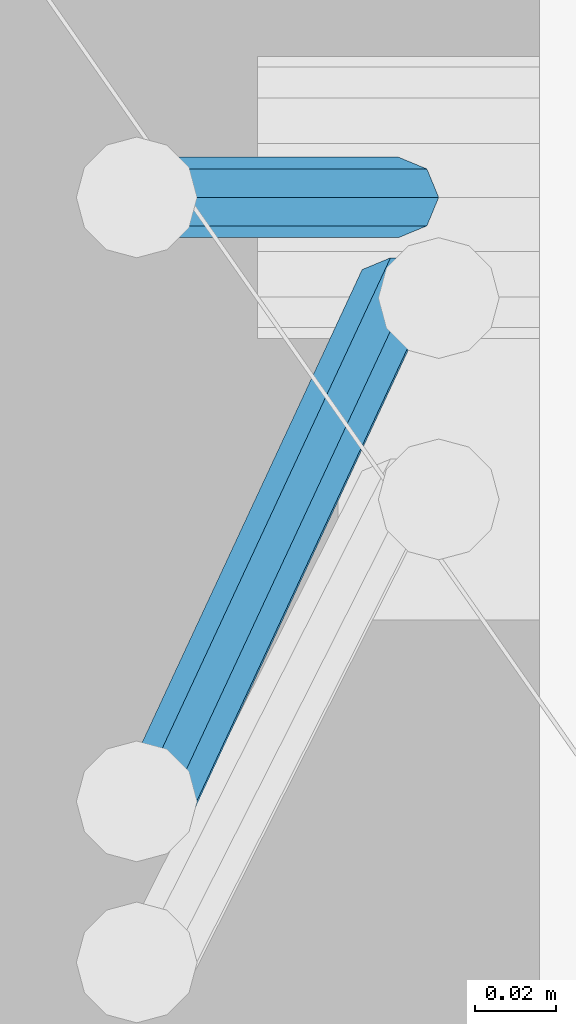
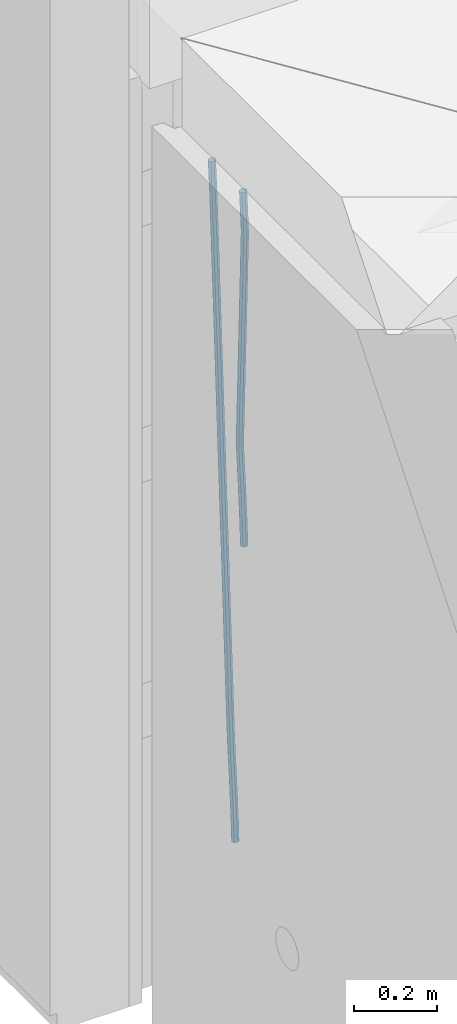
# One storey, part 106 of 309: 2 beams, 1 element without a shape of its own.
"""IFC2X3 building model written with IfcOpenShell, lengths in millimetres."""

from ifc_helpers import new_model, si_unit, frame, origin_with_axes, place, context, subcontext, project, spatial, faceted_brep, material, type_object, element, aggregate, save


model = new_model("IFC2X3")

# Units and contexts
model_context = context("Model", 3, precision=1e-05, world=origin_with_axes())
body_context = subcontext(model_context, "Body", "Model", "MODEL_VIEW")
ifc_project = project(units=[si_unit("LENGTHUNIT", "METRE", prefix="MILLI"), si_unit("AREAUNIT", "SQUARE_METRE"), si_unit("VOLUMEUNIT", "CUBIC_METRE"), si_unit("MASSUNIT", "GRAM", prefix="KILO"), si_unit("TIMEUNIT", "SECOND"), si_unit("PLANEANGLEUNIT", "RADIAN"), si_unit("SOLIDANGLEUNIT", "STERADIAN"), si_unit("THERMODYNAMICTEMPERATUREUNIT", "DEGREE_CELSIUS"), si_unit("LUMINOUSINTENSITYUNIT", "LUMEN")], contexts=[model_context])

# Site, building, storey
site_placement = place(None, origin_with_axes())
site = spatial("IfcSite", under=ifc_project, at=site_placement, CompositionType="ELEMENT")
building_placement = place(site_placement, origin_with_axes())
building = spatial("IfcBuilding", under=site, at=building_placement, CompositionType="ELEMENT")
storey_placement = place(building_placement, origin_with_axes())
storey = spatial("IfcBuildingStorey", under=building, at=storey_placement, Name="7", CompositionType="ELEMENT", Elevation=0.0)

# Assembly, beams
assembly_placement = place(storey_placement, origin_with_axes())
assembly = element("IfcElementAssembly", 1, at=assembly_placement, inside=storey, Name="W1", AssemblyPlace="NOTDEFINED", PredefinedType="REINFORCEMENT_UNIT")
ifc_material = material()
beam_type = type_object("IfcBeamType", Name="D20", PredefinedType="NOTDEFINED")
beam_1_placement = place(assembly_placement, frame((22385.0000022791, 20260.0000000039, 101267.5), z_axis=(-0.999642804636942, -0.000205726999925762, -0.0267249099902983), x_axis=(-0.0267249099948371, 4.30000201934385e-08, 0.999642825806181)))
beam_1 = element("IfcBeam", 2, at=beam_1_placement, type_object=beam_type, material=ifc_material, Name="JM20", ObjectType="D20", context=body_context, shape_type="Brep", body=[
    faceted_brep([(0.0, -10.0, 0.0), (-4.19531716033816e-08, -7.07106781186667, -7.07106781187031), (60.4266690400545, -7.0710677960451, -7.07106780570757), (60.4266690441291, -9.99999998418934, 6.15546014159918e-09), (0.0, 0.0, -10.0), (60.426669036824, 1.58106558956206e-08, -9.99999999384454), (4.196772351861e-08, 7.07106781186303, -7.07106781186667), (60.4266690363438, 7.07106782768096, -7.07106780570757), (0.0, 10.0, 0.0), (60.4266690388904, 10.0000000158179, 6.15182216279209e-09), (4.196772351861e-08, 7.07106781185939, 7.07106781185939), (60.4266690429649, 7.07106782768096, 7.07106781802577), (0.0, 0.0, 10.0), (60.4266690461809, 1.58179318532348e-08, 10.0000000061555), (-4.19531716033816e-08, -7.07106781187031, 7.07106781185939), (60.4266690466611, -7.07106779605238, 7.07106781802213), (61.0378400410118, -7.07106779588503, -7.07106780564936), (60.991799419251, -9.99999998403655, 6.21366780251265e-09), (61.0569027789461, 1.5985278878361e-08, -9.99999999378269), (61.0378209396877, 7.07106782784831, -7.07106780564936), (60.9917724058905, 10.0000000159635, 6.21366780251265e-09), (60.9457317841297, 7.07106782781193, 7.0710678180767), (60.9266690461809, 1.59488990902901e-08, 10.0000000062028), (60.9457508854539, -7.07106779591413, 7.0710678180767), (61.6489592143771, -7.07106614513759, -7.06310863441468), (61.5568818710308, -9.9999984576425, 0.00735959856683621), (61.6870830769039, 1.71821739058942e-06, -9.99179257185824), (61.6489210170112, 7.07106947854481, -7.06310888312146), (61.556827851804, 10.0000015422847, 0.00735924683976918), (61.4647505084577, 7.07106922979438, 7.07782747982128), (61.4266266459163, 1.36643211590126e-06, 10.0065114172685), (61.464788705809, -7.07106639389531, 7.07782772852806), (176.543135720174, -7.07075579406956, -5.56673531796696), (176.451058376813, -9.99968810657447, 1.50373291501455), (176.581259582701, 0.000312069292704109, -8.49541925541052), (176.543097522794, 7.07137982961285, -5.56673556667374), (176.451004357587, 10.00031189336, 1.50373256329476), (176.35892701424, 7.07137958085514, 8.57420079627263), (176.320803151699, 0.000311717507429421, 11.5028847337162), (176.358965211621, -7.07075604281999, 8.57420104497578), (177.098753836006, -7.07075429323595, -5.55949898843028), (176.98362511232, -9.99968666800123, 1.510669025065), (177.146421932586, 0.000313595905026887, -8.48805862247536), (177.098706077581, 7.07138133041735, -5.55949936166144), (176.983557571715, 10.0003133318824, 1.51066849724157), (176.868428848029, 7.07138095712435, 8.58083651073321), (176.820760751449, 0.000313067976094317, 11.5093961447819), (176.868476606425, -7.07075466652896, 8.58083688396073), (177.654312950661, -7.07075204110879, -5.54863964998367), (177.516135294456, -9.99968450931192, 1.52107783331303), (177.711524267797, 0.000315886711177882, -8.47701274570863), (177.654255632195, 7.07138358250813, -5.54864021007961), (177.516054233929, 10.0003154905207, 1.5210770412159), (177.377876577739, 7.0713830223176, 8.59079452451624), (177.320665260588, 0.000315094497636892, 11.5191676202448), (177.377933896176, -7.07075260129932, 8.59079508461218), (298.747348659163, -7.07026115178815, -3.18167234769862), (298.609171002972, -9.99919361999127, 3.88804513559444), (298.804559976241, 0.000806776042736601, -6.11004544342359), (298.747291340609, 7.07187447182878, -3.18167290779093), (298.6090899423, 10.0008063798487, 3.88804434350459), (298.470912286124, 7.07187391164553, 10.9577618268013), (298.413700969017, 0.000805983818281675, 13.8861349225299), (298.470969604663, -7.07026171197504, 10.9577623868936), (299.621796148553, -7.07025760694523, -3.16457979895495), (299.109075512111, -9.99919159347337, 3.89781661105735), (300.339527547287, 0.000812998507171869, -6.08004191737928), (300.841832389109, 7.07188296269669, -3.14073157581515), (300.834467310124, 10.0008154011011, 3.93154309166857), (300.321746673711, 7.071881414573, 10.9939395016918), (299.604015274963, 0.000810809124232037, 13.9094016201125), (299.10171043314, -7.07025915506892, 10.9700912785447), (300.482221804094, -7.22003554013645, -3.11783764522261), (299.6009640134, -10.0848167054246, 3.92453818520153), (301.849881793387, -0.262100753436243, -5.99799274798715), (302.902787308223, 6.71312382273391, -3.02877132562207), (303.024160577959, 9.61964623225504, 4.05049698233779), (302.142902787265, 6.75486506696689, 11.0928728127619), (300.775242797987, -0.203069719733321, 13.9730279155228), (299.722337283136, -7.17829429590347, 11.0038064931578), (1015.90349195308, -131.756442041384, 35.7470320599059), (1015.02223416237, -134.621223206676, 42.78940789033), (1017.27115194236, -124.798507254684, 32.8668769571414), (1018.3240574572, -117.823282678513, 35.8360983795064), (1018.44543072693, -114.916760268996, 42.915366687459), (1017.56417293624, -117.781541434284, 49.9577425178868), (1016.19651294696, -124.739476220984, 52.8378976206477), (1015.14360743211, -131.714700797158, 49.8686761982863), (1017.59248966523, -132.050453017066, 35.8387859380055), (1017.08266705039, -134.979891474468, 42.9013397814706), (1018.34688015285, -124.985763814278, 32.9253153045684), (1018.90392679691, -117.924222987145, 35.8675994646364), (1018.93731922821, -115.002385380943, 42.9420882616032), (1018.42749661337, -117.931823838349, 50.0046421050574), (1017.67310612575, -124.996513041137, 52.9181127385018), (1017.11605948168, -132.058053868273, 49.9758285784337), (1019.30904188578, -132.072836907508, 35.8616318370878), (1019.17671408414, -135.007197908155, 42.9292098262158), (1019.44015792056, -125.00002018789, 32.9398659330036), (1019.4932561936, -117.931907859464, 35.8754429544861), (1019.43723245666, -115.008904263857, 42.9487416957491), (1019.30490465506, -117.943265264505, 50.0163196848807), (1019.17378862025, -125.016081984126, 52.9380855889722), (1019.12069034722, -132.084194312552, 50.0025085674824), (1040.41841779022, -132.348103777858, 36.1425802788253), (1040.28608998859, -135.282464778498, 43.2101582679534), (1040.549533825, -125.275287058234, 33.2208143747339), (1040.60263209805, -118.207174729807, 36.15639139622), (1040.54660836112, -115.284171134201, 43.2296901374903), (1040.4142805595, -118.218532134852, 50.2972681266147), (1040.28316452471, -125.291348854476, 53.2190340307025), (1040.23006625166, -132.359461182896, 50.2834570092164), (1041.05380549764, -132.356389251876, 36.1510367669325), (1040.94617491473, -135.291072304968, 43.2189434557404), (1041.1277784054, -125.282827384228, 33.2285103347931), (1041.1247613119, -118.213983309812, 36.1633405068787), (1041.04652158958, -115.290690017111, 43.2363435716397), (1040.93889100666, -118.225373070203, 50.3042502604476), (1040.8649180989, -125.298934937851, 53.226776692587), (1040.86793519241, -132.367779012271, 50.2919465205014), (1041.68924701435, -132.354514251791, 36.1592989706915), (1041.60631558315, -135.289103781222, 43.2275342832399), (1041.70607222033, -125.28113101716, 33.2360113880059), (1041.64693522363, -118.212446044308, 36.1700937543865), (1041.54647767487, -115.289199122199, 43.2428004127432), (1041.46354624369, -118.223788651623, 50.3110357252881), (1041.4467210377, -125.297171886254, 53.2343233079773), (1041.50585803439, -132.365856859102, 50.3002409415931), (1141.71003490323, -132.056251387494, 37.4566732324238), (1141.62710347204, -134.990840916926, 44.5249085449723), (1141.72686010921, -124.982868152867, 34.5333856497382), (1141.66772311251, -117.914183180015, 37.4674680161224), (1141.56726556375, -114.990936257902, 44.5401746744756), (1141.48433413258, -117.92552578733, 51.6084099870168), (1141.46750892658, -124.998909021961, 54.5316975697097), (1141.52664592327, -132.067593994809, 51.5976152033254)], [[[0, 1, 2, 3]], [[1, 4, 5, 2]], [[4, 6, 7, 5]], [[6, 8, 9, 7]], [[8, 10, 11, 9]], [[10, 12, 13, 11]], [[12, 14, 15, 13]], [[14, 0, 3, 15]], [[14, 12, 10, 8, 6, 4, 1, 0]], [[3, 2, 16, 17]], [[2, 5, 18, 16]], [[5, 7, 19, 18]], [[7, 9, 20, 19]], [[9, 11, 21, 20]], [[11, 13, 22, 21]], [[13, 15, 23, 22]], [[15, 3, 17, 23]], [[17, 16, 24, 25]], [[16, 18, 26, 24]], [[18, 19, 27, 26]], [[19, 20, 28, 27]], [[20, 21, 29, 28]], [[21, 22, 30, 29]], [[22, 23, 31, 30]], [[23, 17, 25, 31]], [[25, 24, 32, 33]], [[24, 26, 34, 32]], [[26, 27, 35, 34]], [[27, 28, 36, 35]], [[28, 29, 37, 36]], [[29, 30, 38, 37]], [[30, 31, 39, 38]], [[31, 25, 33, 39]], [[33, 32, 40, 41]], [[32, 34, 42, 40]], [[34, 35, 43, 42]], [[35, 36, 44, 43]], [[36, 37, 45, 44]], [[37, 38, 46, 45]], [[38, 39, 47, 46]], [[39, 33, 41, 47]], [[41, 40, 48, 49]], [[40, 42, 50, 48]], [[42, 43, 51, 50]], [[43, 44, 52, 51]], [[44, 45, 53, 52]], [[45, 46, 54, 53]], [[46, 47, 55, 54]], [[47, 41, 49, 55]], [[49, 48, 56, 57]], [[48, 50, 58, 56]], [[50, 51, 59, 58]], [[51, 52, 60, 59]], [[52, 53, 61, 60]], [[53, 54, 62, 61]], [[54, 55, 63, 62]], [[55, 49, 57, 63]], [[57, 56, 64, 65]], [[56, 58, 66, 64]], [[58, 59, 67, 66]], [[59, 60, 68, 67]], [[60, 61, 69, 68]], [[61, 62, 70, 69]], [[62, 63, 71, 70]], [[63, 57, 65, 71]], [[65, 64, 72, 73]], [[64, 66, 74, 72]], [[66, 67, 75, 74]], [[67, 68, 76, 75]], [[68, 69, 77, 76]], [[69, 70, 78, 77]], [[70, 71, 79, 78]], [[71, 65, 73, 79]], [[73, 72, 80, 81]], [[72, 74, 82, 80]], [[74, 75, 83, 82]], [[75, 76, 84, 83]], [[76, 77, 85, 84]], [[77, 78, 86, 85]], [[78, 79, 87, 86]], [[79, 73, 81, 87]], [[81, 80, 88, 89]], [[80, 82, 90, 88]], [[82, 83, 91, 90]], [[83, 84, 92, 91]], [[84, 85, 93, 92]], [[85, 86, 94, 93]], [[86, 87, 95, 94]], [[87, 81, 89, 95]], [[89, 88, 96, 97]], [[88, 90, 98, 96]], [[90, 91, 99, 98]], [[91, 92, 100, 99]], [[92, 93, 101, 100]], [[93, 94, 102, 101]], [[94, 95, 103, 102]], [[95, 89, 97, 103]], [[97, 96, 104, 105]], [[96, 98, 106, 104]], [[98, 99, 107, 106]], [[99, 100, 108, 107]], [[100, 101, 109, 108]], [[101, 102, 110, 109]], [[102, 103, 111, 110]], [[103, 97, 105, 111]], [[105, 104, 112, 113]], [[104, 106, 114, 112]], [[106, 107, 115, 114]], [[107, 108, 116, 115]], [[108, 109, 117, 116]], [[109, 110, 118, 117]], [[110, 111, 119, 118]], [[111, 105, 113, 119]], [[113, 112, 120, 121]], [[112, 114, 122, 120]], [[114, 115, 123, 122]], [[115, 116, 124, 123]], [[116, 117, 125, 124]], [[117, 118, 126, 125]], [[118, 119, 127, 126]], [[119, 113, 121, 127]], [[121, 120, 128, 129]], [[120, 122, 130, 128]], [[122, 123, 131, 130]], [[123, 124, 132, 131]], [[124, 125, 133, 132]], [[125, 126, 134, 133]], [[126, 127, 135, 134]], [[127, 121, 129, 135]], [[130, 131, 132, 133, 134, 135, 129, 128]]]),
])
beam_2_placement = place(assembly_placement, frame((22375.0000022791, 20285.0000000039, 100390.0), z_axis=(-0.999642804636942, -0.000205726999925762, -0.0267249099902983), x_axis=(-0.0267249099948371, 4.30000201934385e-08, 0.999642825806181)))
beam_2 = element("IfcBeam", 3, at=beam_2_placement, type_object=beam_type, material=ifc_material, Name="JM20", ObjectType="D20", context=body_context, shape_type="Brep", body=[
    faceted_brep([(0.0, -10.0, 0.0), (-4.19531716033816e-08, -7.07106781186667, -7.07106781187031), (60.4266690400545, -7.0710677960451, -7.07106780570757), (60.4266690441291, -9.99999998418934, 6.15546014159918e-09), (0.0, 0.0, -10.0), (60.426669036824, 1.58106558956206e-08, -9.99999999384454), (4.196772351861e-08, 7.07106781186303, -7.07106781186667), (60.4266690363438, 7.07106782768096, -7.07106780570757), (0.0, 10.0, 0.0), (60.4266690388904, 10.0000000158179, 6.15182216279209e-09), (4.196772351861e-08, 7.07106781185939, 7.07106781185939), (60.4266690429649, 7.07106782768096, 7.07106781802577), (0.0, 0.0, 10.0), (60.4266690461809, 1.58179318532348e-08, 10.0000000061555), (-4.19531716033816e-08, -7.07106781187031, 7.07106781185939), (60.4266690466611, -7.07106779605238, 7.07106781802213), (61.0378400410118, -7.07106779588503, -7.07106780564936), (60.991799419251, -9.99999998403655, 6.21366780251265e-09), (61.0569027789461, 1.5985278878361e-08, -9.99999999378269), (61.0378209396877, 7.07106782784831, -7.07106780564936), (60.9917724058905, 10.0000000159635, 6.21366780251265e-09), (60.9457317841297, 7.07106782781193, 7.0710678180767), (60.9266690461809, 1.59488990902901e-08, 10.0000000062028), (60.9457508854539, -7.07106779591413, 7.0710678180767), (61.6489592143771, -7.07106614513759, -7.06310863441468), (61.5568818710308, -9.9999984576425, 0.00735959856683621), (61.6870830769039, 1.71821739058942e-06, -9.99179257185824), (61.6489210170112, 7.07106947854481, -7.06310888312146), (61.556827851804, 10.0000015422847, 0.00735924683976918), (61.4647505084577, 7.07106922979438, 7.07782747982128), (61.4266266459163, 1.36643211590126e-06, 10.0065114172685), (61.464788705809, -7.07106639389531, 7.07782772852806), (176.543135720174, -7.07075579406956, -5.56673531796696), (176.451058376813, -9.99968810657447, 1.50373291501455), (176.581259582701, 0.000312069292704109, -8.49541925541052), (176.543097522794, 7.07137982961285, -5.56673556667374), (176.451004357587, 10.00031189336, 1.50373256329476), (176.35892701424, 7.07137958085514, 8.57420079627263), (176.320803151699, 0.000311717507429421, 11.5028847337162), (176.358965211621, -7.07075604281999, 8.57420104497578), (177.098753836006, -7.07075429323595, -5.55949898843028), (176.98362511232, -9.99968666800123, 1.510669025065), (177.146421932586, 0.000313595905026887, -8.48805862247536), (177.098706077581, 7.07138133041735, -5.55949936166144), (176.983557571715, 10.0003133318824, 1.51066849724157), (176.868428848029, 7.07138095712435, 8.58083651073321), (176.820760751449, 0.000313067976094317, 11.5093961447819), (176.868476606425, -7.07075466652896, 8.58083688396073), (177.654312950661, -7.07075204110879, -5.54863964998367), (177.516135294456, -9.99968450931192, 1.52107783331303), (177.711524267797, 0.000315886711177882, -8.47701274570863), (177.654255632195, 7.07138358250813, -5.54864021007961), (177.516054233929, 10.0003154905207, 1.5210770412159), (177.377876577739, 7.0713830223176, 8.59079452451624), (177.320665260588, 0.000315094497636892, 11.5191676202448), (177.377933896176, -7.07075260129932, 8.59079508461218), (299.529725389817, -7.0702579820354, -3.16637947698109), (299.391547733612, -9.99919045023489, 3.90333800631561), (299.586936706939, 0.000809945799119305, -6.09475257270606), (299.529668071336, 7.07187764158152, -3.16638003707703), (299.391466673056, 10.000809549605, 3.90333721422212), (299.253289016866, 7.07187708140191, 10.9730546975188), (299.196077699729, 0.000809153574664379, 13.9014277932438), (299.253346335332, -7.07025854221502, 10.9730552576111), (300.053154890193, -7.07025586015152, -3.15614816594825), (299.971788958996, -9.99918809853989, 3.91467979818117), (300.086841216093, 0.000811972313385922, -6.08498109724314), (300.053121210876, 7.07187976355999, -3.15614826397359), (299.971753863239, 10.0008119014747, 3.91467990454839), (299.890387932071, 7.07187966407218, 10.9855078686815), (299.856701606172, 0.000811831610917579, 13.9143407999763), (299.890421611388, -7.07025595963933, 10.9855079667068), (300.576681224076, -7.07025548863749, -3.15433176753868), (300.552150063115, -9.99918768617863, 3.91669348816504), (300.586838206684, 0.000812327129096957, -6.08324633496159), (300.57667118829, 7.07188013509221, -3.15433178353487), (300.552135870385, 10.0008123138141, 3.91669346554409), (300.527604709423, 7.07188011626931, 10.9877187212514), (300.517447726816, 0.000812300502730068, 13.9166332886707), (300.52761474521, -7.07025550746039, 10.9877187372476), (1894.37298527778, -7.06912446613933, 2.37541694085667), (1894.34845411681, -9.99805666368775, 9.44644219656402), (1894.3831422604, 0.00194334961997811, -0.553497626566241), (1894.37297524199, 7.07301115758673, 2.37541692486411), (1894.34843992408, 10.0019433363086, 9.44644217394307), (1894.32390876314, 7.07301113876019, 16.5174674296468), (1894.31375178052, 0.00194332300088718, 19.4463819970697), (1894.32391879891, -7.06912448496587, 16.5174674456393), (1894.94254953373, -7.06912406195261, 2.37739306992808), (1894.864138918, -9.99805629773618, 9.44823138841821), (1895.01321576146, 0.00194379674576339, -0.551311557919689), (1895.03474228333, 7.0730116272025, 2.3777129556911), (1894.99451915483, 10.0019437947958, 9.44868377519742), (1894.9161085391, 7.07301155900859, 16.5195220936839), (1894.8454423114, 0.0019437003065832, 19.4482267215244), (1894.8239157895, -7.06912413014652, 16.5192022079245), (1895.51201837322, -7.07655005247943, 2.3849721376755), (1895.3797373289, -10.0047798068154, 9.45509349396525), (1895.6431837092, -0.00627111456196872, -0.542927306803904), (1895.69639846191, 7.06438349486052, 2.38651894584837), (1895.64049015092, 9.99352020044898, 9.45728101107306), (1895.50820910657, 7.06529044610943, 16.5274023673664), (1895.37704377061, -0.00498849180803518, 19.4553018118422), (1895.3238290179, -7.07564310123053, 16.5258555591899), (1917.3375872656, -7.36115994941429, 2.67544890068893), (1917.20530622125, -10.2893897037538, 9.74557025698232), (1917.46875260158, -0.29088101150046, -0.252450543786836), (1917.52196735426, 6.77977359792203, 2.67699570887271), (1917.46605904329, 9.70891030351049, 9.74775777409013), (1917.33377799895, 6.78068054917094, 16.8178791303835), (1917.20261266298, -0.289598388742888, 19.7457785748593), (1917.1493979103, -7.36025299817265, 16.816332322207), (1917.97302879854, -7.36944623740055, 2.68390599981285), (1917.86539582294, -10.2979974076115, 9.75435539755927), (1918.04706999661, -0.298422389005282, -0.244753710507212), (1918.04414708749, 6.77296426705288, 2.68394540532245), (1917.9659722717, 9.70239133243012, 9.75441112535555), (1917.85833929609, 6.77384016221913, 16.824860523102), (1917.78429809801, -0.297183686179778, 19.753520233422), (1917.78722100714, -7.36857034223431, 16.8248211175924), (1918.60852415283, -7.36757026622581, 2.69216814523315), (1918.52554118163, -10.29602885028, 9.76294518245413), (1918.62543662851, -0.296724680512853, -0.237251666560041), (1918.56637150982, 6.77450246020453, 2.69070014292447), (1918.46592834221, 9.70388219950109, 9.76086911367383), (1918.38294537101, 6.7754236154542, 16.8316461508839), (1918.36603289531, -0.295421970262396, 19.7610659626844), (1918.42509801401, -7.36664911097978, 16.8331141531962), (2018.62930980593, -7.06930811566781, 3.98954616814444), (2018.54632683474, -9.99776669972198, 11.0603232053618), (2018.64622228162, 0.00153747004878824, 1.06012635634761), (2018.58715716293, 7.07276461076617, 3.98807816583212), (2018.4867139953, 10.0021443500664, 11.0582471365815), (2018.40373102411, 7.0736857660122, 18.1290241737915), (2018.38681854842, 0.00284018029924482, 21.0584439855957), (2018.44588366711, -7.06838696041814, 18.1304921761075)], [[[0, 1, 2, 3]], [[1, 4, 5, 2]], [[4, 6, 7, 5]], [[6, 8, 9, 7]], [[8, 10, 11, 9]], [[10, 12, 13, 11]], [[12, 14, 15, 13]], [[14, 0, 3, 15]], [[14, 12, 10, 8, 6, 4, 1, 0]], [[3, 2, 16, 17]], [[2, 5, 18, 16]], [[5, 7, 19, 18]], [[7, 9, 20, 19]], [[9, 11, 21, 20]], [[11, 13, 22, 21]], [[13, 15, 23, 22]], [[15, 3, 17, 23]], [[17, 16, 24, 25]], [[16, 18, 26, 24]], [[18, 19, 27, 26]], [[19, 20, 28, 27]], [[20, 21, 29, 28]], [[21, 22, 30, 29]], [[22, 23, 31, 30]], [[23, 17, 25, 31]], [[25, 24, 32, 33]], [[24, 26, 34, 32]], [[26, 27, 35, 34]], [[27, 28, 36, 35]], [[28, 29, 37, 36]], [[29, 30, 38, 37]], [[30, 31, 39, 38]], [[31, 25, 33, 39]], [[33, 32, 40, 41]], [[32, 34, 42, 40]], [[34, 35, 43, 42]], [[35, 36, 44, 43]], [[36, 37, 45, 44]], [[37, 38, 46, 45]], [[38, 39, 47, 46]], [[39, 33, 41, 47]], [[41, 40, 48, 49]], [[40, 42, 50, 48]], [[42, 43, 51, 50]], [[43, 44, 52, 51]], [[44, 45, 53, 52]], [[45, 46, 54, 53]], [[46, 47, 55, 54]], [[47, 41, 49, 55]], [[49, 48, 56, 57]], [[48, 50, 58, 56]], [[50, 51, 59, 58]], [[51, 52, 60, 59]], [[52, 53, 61, 60]], [[53, 54, 62, 61]], [[54, 55, 63, 62]], [[55, 49, 57, 63]], [[57, 56, 64, 65]], [[56, 58, 66, 64]], [[58, 59, 67, 66]], [[59, 60, 68, 67]], [[60, 61, 69, 68]], [[61, 62, 70, 69]], [[62, 63, 71, 70]], [[63, 57, 65, 71]], [[65, 64, 72, 73]], [[64, 66, 74, 72]], [[66, 67, 75, 74]], [[67, 68, 76, 75]], [[68, 69, 77, 76]], [[69, 70, 78, 77]], [[70, 71, 79, 78]], [[71, 65, 73, 79]], [[73, 72, 80, 81]], [[72, 74, 82, 80]], [[74, 75, 83, 82]], [[75, 76, 84, 83]], [[76, 77, 85, 84]], [[77, 78, 86, 85]], [[78, 79, 87, 86]], [[79, 73, 81, 87]], [[81, 80, 88, 89]], [[80, 82, 90, 88]], [[82, 83, 91, 90]], [[83, 84, 92, 91]], [[84, 85, 93, 92]], [[85, 86, 94, 93]], [[86, 87, 95, 94]], [[87, 81, 89, 95]], [[89, 88, 96, 97]], [[88, 90, 98, 96]], [[90, 91, 99, 98]], [[91, 92, 100, 99]], [[92, 93, 101, 100]], [[93, 94, 102, 101]], [[94, 95, 103, 102]], [[95, 89, 97, 103]], [[97, 96, 104, 105]], [[96, 98, 106, 104]], [[98, 99, 107, 106]], [[99, 100, 108, 107]], [[100, 101, 109, 108]], [[101, 102, 110, 109]], [[102, 103, 111, 110]], [[103, 97, 105, 111]], [[105, 104, 112, 113]], [[104, 106, 114, 112]], [[106, 107, 115, 114]], [[107, 108, 116, 115]], [[108, 109, 117, 116]], [[109, 110, 118, 117]], [[110, 111, 119, 118]], [[111, 105, 113, 119]], [[113, 112, 120, 121]], [[112, 114, 122, 120]], [[114, 115, 123, 122]], [[115, 116, 124, 123]], [[116, 117, 125, 124]], [[117, 118, 126, 125]], [[118, 119, 127, 126]], [[119, 113, 121, 127]], [[121, 120, 128, 129]], [[120, 122, 130, 128]], [[122, 123, 131, 130]], [[123, 124, 132, 131]], [[124, 125, 133, 132]], [[125, 126, 134, 133]], [[126, 127, 135, 134]], [[127, 121, 129, 135]], [[130, 131, 132, 133, 134, 135, 129, 128]]]),
])
aggregate(assembly, [beam_1, beam_2])

save(model, "model.ifc")
